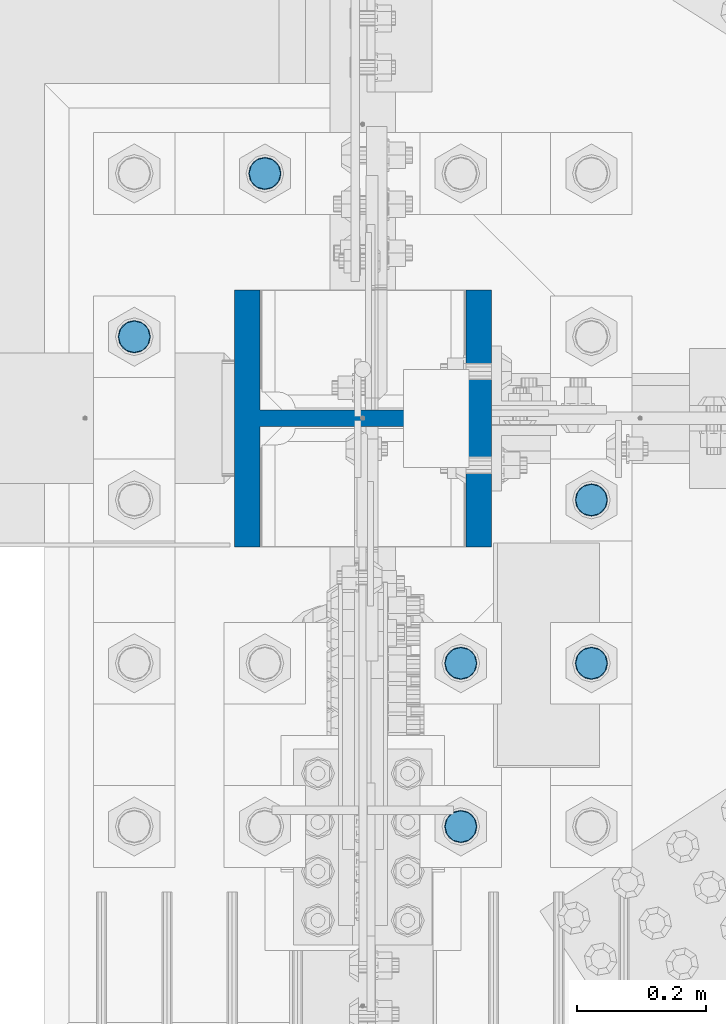
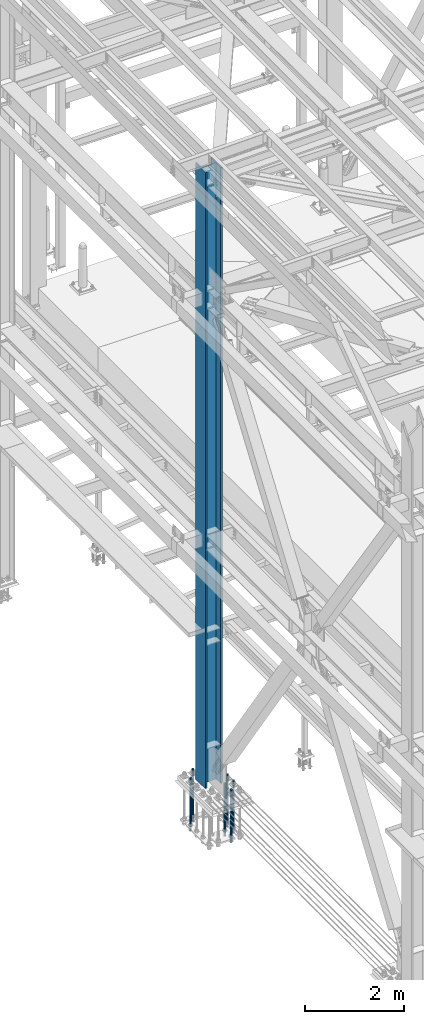
# One storey, part 1358 of 3843: 7 columns, 2 elements without a shape of their own.
"""IFC2X3 building model written with IfcOpenShell, lengths in millimetres."""

from ifc_helpers import new_model, si_unit, frame, origin_with_axes, place, context, subcontext, project, spatial, faceted_brep, material, type_object, element, aggregate, save


model = new_model("IFC2X3")

# Units and contexts
model_context = context("Model", 3, precision=1e-05, world=origin_with_axes())
body_context = subcontext(model_context, "Body", "Model", "MODEL_VIEW")
ifc_project = project(units=[si_unit("LENGTHUNIT", "METRE", prefix="MILLI"), si_unit("AREAUNIT", "SQUARE_METRE"), si_unit("VOLUMEUNIT", "CUBIC_METRE"), si_unit("MASSUNIT", "GRAM", prefix="KILO"), si_unit("TIMEUNIT", "SECOND"), si_unit("PLANEANGLEUNIT", "RADIAN"), si_unit("SOLIDANGLEUNIT", "STERADIAN"), si_unit("THERMODYNAMICTEMPERATUREUNIT", "DEGREE_CELSIUS"), si_unit("LUMINOUSINTENSITYUNIT", "LUMEN")], contexts=[model_context])

# Site, building, storey
site_placement = place(None, origin_with_axes())
site = spatial("IfcSite", under=ifc_project, at=site_placement, CompositionType="ELEMENT")
building_placement = place(site_placement, origin_with_axes())
building = spatial("IfcBuilding", under=site, at=building_placement, Name="Undefined", CompositionType="ELEMENT")
storey_placement = place(building_placement, origin_with_axes())
storey = spatial("IfcBuildingStorey", under=building, at=storey_placement, Name="Undefined", CompositionType="ELEMENT", Elevation=0.0)

# Assembly, columns
assembly_1_placement = place(storey_placement, origin_with_axes())
assembly_1 = element("IfcElementAssembly", 1, at=assembly_1_placement, inside=storey, Name="TEMPLATE", AssemblyPlace="NOTDEFINED", PredefinedType="RIGID_FRAME")
ifc_material_1 = material(Name="Undefined/F1554-GR.55")
column_type_1 = type_object("IfcColumnType", PredefinedType="NOTDEFINED")
column_1_placement = place(assembly_1_placement, frame((36931.6, 75247.5, 30022.8), z_axis=(1.0, 0.0, 0.0), x_axis=(0.0, 0.0, -1.0)))
column_1 = element("IfcColumn", 2, at=column_1_placement, type_object=column_type_1, material=ifc_material_1, Name="ANCHOR_ROD", context=body_context, shape_type="Brep", body=[
    faceted_brep([(-266.700000000001, -21.2176223927236, 12.25), (-266.700000000001, -12.25, 21.2176223927163), (-266.700000000001, 0.0, 24.5), (-266.700000000001, 12.25, 21.2176223927163), (-266.700000000001, 21.2176223927236, 12.25), (-266.700000000001, 24.5, 0.0), (-266.700000000001, 21.2176223927236, -12.25), (-266.700000000001, 12.25, -21.2176223927163), (-266.700000000001, 0.0, -24.5), (-266.700000000001, -12.25, -21.2176223927163), (-266.700000000001, -21.2176223927236, -12.25), (-266.700000000001, -24.5, 0.0), (0.0, 24.5000000000146, 0.0), (0.0, 21.2176223927381, -12.25), (0.0, 12.2500000000146, -21.2176223927163), (0.0, 1.45519152283669e-11, -24.5), (0.0, -12.2499999999854, -21.2176223927163), (0.0, -21.217622392709, -12.25), (0.0, -24.4999999999854, 0.0), (0.0, -21.217622392709, 12.25), (0.0, -12.2499999999854, 21.2176223927163), (0.0, 1.45519152283669e-11, 24.5), (0.0, 12.2500000000146, 21.2176223927163), (0.0, 21.2176223927381, 12.25), (0.0, -23.4665401257807, 9.72015918207035), (0.0, -17.9605122421344, 17.9605122421417), (0.0, -9.72015918207762, 23.466540125788), (0.0, 0.0, 25.4000000000015), (0.0, 9.72015918207762, 23.466540125788), (0.0, 17.9605122421344, 17.9605122421417), (0.0, 23.4665401257807, 9.72015918207035), (0.0, 25.3999996185303, 0.0), (0.0, 23.4665401257807, -9.72015918207035), (0.0, 17.9605122421344, -17.9605122421417), (0.0, 9.72015918207762, -23.466540125788), (0.0, 0.0, -25.4000000000015), (0.0, -9.72015918207762, -23.466540125788), (0.0, -17.9605122421344, -17.9605122421417), (0.0, -23.4665401257807, -9.72015918207035), (0.0, -25.3999996185303, 0.0), (812.799999999999, -25.4000000000015, 0.0), (812.799999999999, -23.466540125788, 9.72015918207398), (812.799999999999, -17.9605122421417, 17.9605122421381), (812.799999999999, -9.72015918207035, 23.466540125788), (812.799999999999, 0.0, 25.4000000000015), (812.799999999999, 9.72015918207035, 23.466540125788), (812.799999999999, 17.9605122421417, 17.9605122421381), (812.799999999999, 23.466540125788, 9.72015918207398), (812.799999999999, 25.4000000000015, 0.0), (812.799999999999, 23.466540125788, -9.72015918207398), (812.799999999999, 17.9605122421417, -17.9605122421381), (812.799999999999, 9.72015918207035, -23.466540125788), (812.799999999999, 0.0, -25.4000000000015), (812.799999999999, -9.72015918207035, -23.466540125788), (812.799999999999, -17.9605122421417, -17.9605122421381), (812.799999999999, -23.466540125788, -9.72015918207398), (812.799999999999, -12.25, 21.2176223927199), (812.799999999999, 0.0, 24.5), (812.799999999999, 12.25, 21.2176223927199), (812.799999999999, 21.2176223927163, 12.25), (812.799999999999, 24.5, 0.0), (812.799999999999, 21.2176223927163, -12.25), (812.799999999999, 12.25, -21.2176223927199), (812.799999999999, 0.0, -24.5), (812.799999999999, -12.25, -21.2176223927199), (812.799999999999, -21.2176223927163, -12.25), (812.799999999999, -24.5, 0.0), (812.799999999999, -21.2176223927163, 12.25), (1041.4, -12.25, -21.2176223927199), (1041.4, 0.0, -24.5), (1041.4, 12.25, -21.2176223927199), (1041.4, 21.2176223927163, -12.25), (1041.4, 24.5, 0.0), (1041.4, 21.2176223927163, 12.25), (1041.4, 12.25, 21.2176223927199), (1041.4, 0.0, 24.5), (1041.4, -12.25, 21.2176223927199), (1041.4, -21.2176223927163, 12.25), (1041.4, -24.5, 0.0), (1041.4, -21.2176223927163, -12.25)], [[[0, 1, 2, 3, 4, 5, 6, 7, 8, 9, 10, 11]], [[6, 5, 12, 13]], [[7, 6, 13, 14]], [[8, 7, 14, 15]], [[9, 8, 15, 16]], [[10, 9, 16, 17]], [[11, 10, 17, 18]], [[0, 11, 18, 19]], [[1, 0, 19, 20]], [[2, 1, 20, 21]], [[3, 2, 21, 22]], [[4, 3, 22, 23]], [[5, 4, 23, 12]], [[24, 25, 26, 27, 28, 29, 30, 31, 32, 33, 34, 35, 36, 37, 38, 39], [22, 21, 20, 19, 18, 17, 16, 15, 14, 13, 12, 23]], [[24, 39, 40, 41]], [[25, 24, 41, 42]], [[26, 25, 42, 43]], [[27, 26, 43, 44]], [[28, 27, 44, 45]], [[29, 28, 45, 46]], [[30, 29, 46, 47]], [[31, 30, 47, 48]], [[32, 31, 48, 49]], [[33, 32, 49, 50]], [[34, 33, 50, 51]], [[35, 34, 51, 52]], [[36, 35, 52, 53]], [[37, 36, 53, 54]], [[38, 37, 54, 55]], [[39, 38, 55, 40]], [[54, 53, 52, 51, 50, 49, 48, 47, 46, 45, 44, 43, 42, 41, 40, 55], [56, 57, 58, 59, 60, 61, 62, 63, 64, 65, 66, 67]], [[68, 69, 70, 71, 72, 73, 74, 75, 76, 77, 78, 79]], [[76, 75, 57, 56]], [[77, 76, 56, 67]], [[78, 77, 67, 66]], [[79, 78, 66, 65]], [[68, 79, 65, 64]], [[69, 68, 64, 63]], [[70, 69, 63, 62]], [[71, 70, 62, 61]], [[72, 71, 61, 60]], [[73, 72, 60, 59]], [[74, 73, 59, 58]], [[75, 74, 58, 57]]]),
])
column_2_placement = place(assembly_1_placement, frame((36931.6, 75501.5, 30022.8), z_axis=(1.0, 0.0, 0.0), x_axis=(0.0, 0.0, -1.0)))
column_2 = element("IfcColumn", 3, at=column_2_placement, type_object=column_type_1, material=ifc_material_1, Name="ANCHOR_ROD", context=body_context, shape_type="Brep", body=[
    faceted_brep([(-266.700000000001, -21.2176223927236, 12.25), (-266.700000000001, -12.25, 21.2176223927163), (-266.700000000001, 0.0, 24.5), (-266.700000000001, 12.25, 21.2176223927163), (-266.700000000001, 21.2176223927236, 12.25), (-266.700000000001, 24.5, 0.0), (-266.700000000001, 21.2176223927236, -12.25), (-266.700000000001, 12.25, -21.2176223927163), (-266.700000000001, 0.0, -24.5), (-266.700000000001, -12.25, -21.2176223927163), (-266.700000000001, -21.2176223927236, -12.25), (-266.700000000001, -24.5, 0.0), (0.0, 24.5000000000146, 0.0), (0.0, 21.2176223927381, -12.25), (0.0, 12.2500000000146, -21.2176223927163), (0.0, 1.45519152283669e-11, -24.5), (0.0, -12.2499999999854, -21.2176223927163), (0.0, -21.217622392709, -12.25), (0.0, -24.4999999999854, 0.0), (0.0, -21.217622392709, 12.25), (0.0, -12.2499999999854, 21.2176223927163), (0.0, 1.45519152283669e-11, 24.5), (0.0, 12.2500000000146, 21.2176223927163), (0.0, 21.2176223927381, 12.25), (0.0, -23.4665401257807, 9.72015918207035), (0.0, -17.9605122421344, 17.9605122421417), (0.0, -9.72015918207762, 23.466540125788), (0.0, 0.0, 25.4000000000015), (0.0, 9.72015918207762, 23.466540125788), (0.0, 17.9605122421344, 17.9605122421417), (0.0, 23.4665401257807, 9.72015918207035), (0.0, 25.3999996185303, 0.0), (0.0, 23.4665401257807, -9.72015918207035), (0.0, 17.9605122421344, -17.9605122421417), (0.0, 9.72015918207762, -23.466540125788), (0.0, 0.0, -25.4000000000015), (0.0, -9.72015918207762, -23.466540125788), (0.0, -17.9605122421344, -17.9605122421417), (0.0, -23.4665401257807, -9.72015918207035), (0.0, -25.3999996185303, 0.0), (812.799999999999, -25.4000000000015, 0.0), (812.799999999999, -23.466540125788, 9.72015918207398), (812.799999999999, -17.9605122421417, 17.9605122421381), (812.799999999999, -9.72015918207035, 23.466540125788), (812.799999999999, 0.0, 25.4000000000015), (812.799999999999, 9.72015918207035, 23.466540125788), (812.799999999999, 17.9605122421417, 17.9605122421381), (812.799999999999, 23.466540125788, 9.72015918207398), (812.799999999999, 25.4000000000015, 0.0), (812.799999999999, 23.466540125788, -9.72015918207398), (812.799999999999, 17.9605122421417, -17.9605122421381), (812.799999999999, 9.72015918207035, -23.466540125788), (812.799999999999, 0.0, -25.4000000000015), (812.799999999999, -9.72015918207035, -23.466540125788), (812.799999999999, -17.9605122421417, -17.9605122421381), (812.799999999999, -23.466540125788, -9.72015918207398), (812.799999999999, -12.25, 21.2176223927199), (812.799999999999, 0.0, 24.5), (812.799999999999, 12.25, 21.2176223927199), (812.799999999999, 21.2176223927163, 12.25), (812.799999999999, 24.5, 0.0), (812.799999999999, 21.2176223927163, -12.25), (812.799999999999, 12.25, -21.2176223927199), (812.799999999999, 0.0, -24.5), (812.799999999999, -12.25, -21.2176223927199), (812.799999999999, -21.2176223927163, -12.25), (812.799999999999, -24.5, 0.0), (812.799999999999, -21.2176223927163, 12.25), (1041.4, -12.25, -21.2176223927199), (1041.4, 0.0, -24.5), (1041.4, 12.25, -21.2176223927199), (1041.4, 21.2176223927163, -12.25), (1041.4, 24.5, 0.0), (1041.4, 21.2176223927163, 12.25), (1041.4, 12.25, 21.2176223927199), (1041.4, 0.0, 24.5), (1041.4, -12.25, 21.2176223927199), (1041.4, -21.2176223927163, 12.25), (1041.4, -24.5, 0.0), (1041.4, -21.2176223927163, -12.25)], [[[0, 1, 2, 3, 4, 5, 6, 7, 8, 9, 10, 11]], [[6, 5, 12, 13]], [[7, 6, 13, 14]], [[8, 7, 14, 15]], [[9, 8, 15, 16]], [[10, 9, 16, 17]], [[11, 10, 17, 18]], [[0, 11, 18, 19]], [[1, 0, 19, 20]], [[2, 1, 20, 21]], [[3, 2, 21, 22]], [[4, 3, 22, 23]], [[5, 4, 23, 12]], [[24, 25, 26, 27, 28, 29, 30, 31, 32, 33, 34, 35, 36, 37, 38, 39], [22, 21, 20, 19, 18, 17, 16, 15, 14, 13, 12, 23]], [[24, 39, 40, 41]], [[25, 24, 41, 42]], [[26, 25, 42, 43]], [[27, 26, 43, 44]], [[28, 27, 44, 45]], [[29, 28, 45, 46]], [[30, 29, 46, 47]], [[31, 30, 47, 48]], [[32, 31, 48, 49]], [[33, 32, 49, 50]], [[34, 33, 50, 51]], [[35, 34, 51, 52]], [[36, 35, 52, 53]], [[37, 36, 53, 54]], [[38, 37, 54, 55]], [[39, 38, 55, 40]], [[54, 53, 52, 51, 50, 49, 48, 47, 46, 45, 44, 43, 42, 41, 40, 55], [56, 57, 58, 59, 60, 61, 62, 63, 64, 65, 66, 67]], [[68, 69, 70, 71, 72, 73, 74, 75, 76, 77, 78, 79]], [[76, 75, 57, 56]], [[77, 76, 56, 67]], [[78, 77, 67, 66]], [[79, 78, 66, 65]], [[68, 79, 65, 64]], [[69, 68, 64, 63]], [[70, 69, 63, 62]], [[71, 70, 62, 61]], [[72, 71, 61, 60]], [[73, 72, 60, 59]], [[74, 73, 59, 58]], [[75, 74, 58, 57]]]),
])
column_3_placement = place(assembly_1_placement, frame((36728.4, 74993.5, 30022.8), z_axis=(1.0, 0.0, 0.0), x_axis=(0.0, 0.0, -1.0)))
column_3 = element("IfcColumn", 4, at=column_3_placement, type_object=column_type_1, material=ifc_material_1, Name="ANCHOR_ROD", context=body_context, shape_type="Brep", body=[
    faceted_brep([(-266.700000000001, -21.2176223927236, 12.25), (-266.700000000001, -12.25, 21.2176223927163), (-266.700000000001, 0.0, 24.5), (-266.700000000001, 12.25, 21.2176223927163), (-266.700000000001, 21.2176223927236, 12.25), (-266.700000000001, 24.5, 0.0), (-266.700000000001, 21.2176223927236, -12.25), (-266.700000000001, 12.25, -21.2176223927163), (-266.700000000001, 0.0, -24.5), (-266.700000000001, -12.25, -21.2176223927163), (-266.700000000001, -21.2176223927236, -12.25), (-266.700000000001, -24.5, 0.0), (0.0, 24.5000000000146, 0.0), (0.0, 21.2176223927381, -12.25), (0.0, 12.2500000000146, -21.2176223927163), (0.0, 1.45519152283669e-11, -24.5), (0.0, -12.2499999999854, -21.2176223927163), (0.0, -21.217622392709, -12.25), (0.0, -24.4999999999854, 0.0), (0.0, -21.217622392709, 12.25), (0.0, -12.2499999999854, 21.2176223927163), (0.0, 1.45519152283669e-11, 24.5), (0.0, 12.2500000000146, 21.2176223927163), (0.0, 21.2176223927381, 12.25), (0.0, -23.4665401257807, 9.72015918207035), (0.0, -17.9605122421344, 17.9605122421417), (0.0, -9.72015918207762, 23.466540125788), (0.0, 0.0, 25.4000000000015), (0.0, 9.72015918207762, 23.466540125788), (0.0, 17.9605122421344, 17.9605122421417), (0.0, 23.4665401257807, 9.72015918207035), (0.0, 25.3999996185303, 0.0), (0.0, 23.4665401257807, -9.72015918207035), (0.0, 17.9605122421344, -17.9605122421417), (0.0, 9.72015918207762, -23.466540125788), (0.0, 0.0, -25.4000000000015), (0.0, -9.72015918207762, -23.466540125788), (0.0, -17.9605122421344, -17.9605122421417), (0.0, -23.4665401257807, -9.72015918207035), (0.0, -25.3999996185303, 0.0), (812.799999999999, -25.4000000000015, 0.0), (812.799999999999, -23.466540125788, 9.72015918207398), (812.799999999999, -17.9605122421417, 17.9605122421381), (812.799999999999, -9.72015918207035, 23.466540125788), (812.799999999999, 0.0, 25.4000000000015), (812.799999999999, 9.72015918207035, 23.466540125788), (812.799999999999, 17.9605122421417, 17.9605122421381), (812.799999999999, 23.466540125788, 9.72015918207398), (812.799999999999, 25.4000000000015, 0.0), (812.799999999999, 23.466540125788, -9.72015918207398), (812.799999999999, 17.9605122421417, -17.9605122421381), (812.799999999999, 9.72015918207035, -23.466540125788), (812.799999999999, 0.0, -25.4000000000015), (812.799999999999, -9.72015918207035, -23.466540125788), (812.799999999999, -17.9605122421417, -17.9605122421381), (812.799999999999, -23.466540125788, -9.72015918207398), (812.799999999999, -12.25, 21.2176223927199), (812.799999999999, 0.0, 24.5), (812.799999999999, 12.25, 21.2176223927199), (812.799999999999, 21.2176223927163, 12.25), (812.799999999999, 24.5, 0.0), (812.799999999999, 21.2176223927163, -12.25), (812.799999999999, 12.25, -21.2176223927199), (812.799999999999, 0.0, -24.5), (812.799999999999, -12.25, -21.2176223927199), (812.799999999999, -21.2176223927163, -12.25), (812.799999999999, -24.5, 0.0), (812.799999999999, -21.2176223927163, 12.25), (1041.4, -12.25, -21.2176223927199), (1041.4, 0.0, -24.5), (1041.4, 12.25, -21.2176223927199), (1041.4, 21.2176223927163, -12.25), (1041.4, 24.5, 0.0), (1041.4, 21.2176223927163, 12.25), (1041.4, 12.25, 21.2176223927199), (1041.4, 0.0, 24.5), (1041.4, -12.25, 21.2176223927199), (1041.4, -21.2176223927163, 12.25), (1041.4, -24.5, 0.0), (1041.4, -21.2176223927163, -12.25)], [[[0, 1, 2, 3, 4, 5, 6, 7, 8, 9, 10, 11]], [[6, 5, 12, 13]], [[7, 6, 13, 14]], [[8, 7, 14, 15]], [[9, 8, 15, 16]], [[10, 9, 16, 17]], [[11, 10, 17, 18]], [[0, 11, 18, 19]], [[1, 0, 19, 20]], [[2, 1, 20, 21]], [[3, 2, 21, 22]], [[4, 3, 22, 23]], [[5, 4, 23, 12]], [[24, 25, 26, 27, 28, 29, 30, 31, 32, 33, 34, 35, 36, 37, 38, 39], [22, 21, 20, 19, 18, 17, 16, 15, 14, 13, 12, 23]], [[24, 39, 40, 41]], [[25, 24, 41, 42]], [[26, 25, 42, 43]], [[27, 26, 43, 44]], [[28, 27, 44, 45]], [[29, 28, 45, 46]], [[30, 29, 46, 47]], [[31, 30, 47, 48]], [[32, 31, 48, 49]], [[33, 32, 49, 50]], [[34, 33, 50, 51]], [[35, 34, 51, 52]], [[36, 35, 52, 53]], [[37, 36, 53, 54]], [[38, 37, 54, 55]], [[39, 38, 55, 40]], [[54, 53, 52, 51, 50, 49, 48, 47, 46, 45, 44, 43, 42, 41, 40, 55], [56, 57, 58, 59, 60, 61, 62, 63, 64, 65, 66, 67]], [[68, 69, 70, 71, 72, 73, 74, 75, 76, 77, 78, 79]], [[76, 75, 57, 56]], [[77, 76, 56, 67]], [[78, 77, 67, 66]], [[79, 78, 66, 65]], [[68, 79, 65, 64]], [[69, 68, 64, 63]], [[70, 69, 63, 62]], [[71, 70, 62, 61]], [[72, 71, 61, 60]], [[73, 72, 60, 59]], [[74, 73, 59, 58]], [[75, 74, 58, 57]]]),
])
column_4_placement = place(assembly_1_placement, frame((36728.4, 75247.5, 30022.8), z_axis=(1.0, 0.0, 0.0), x_axis=(0.0, 0.0, -1.0)))
column_4 = element("IfcColumn", 5, at=column_4_placement, type_object=column_type_1, material=ifc_material_1, Name="ANCHOR_ROD", context=body_context, shape_type="Brep", body=[
    faceted_brep([(-266.700000000001, -21.2176223927236, 12.25), (-266.700000000001, -12.25, 21.2176223927163), (-266.700000000001, 0.0, 24.5), (-266.700000000001, 12.25, 21.2176223927163), (-266.700000000001, 21.2176223927236, 12.25), (-266.700000000001, 24.5, 0.0), (-266.700000000001, 21.2176223927236, -12.25), (-266.700000000001, 12.25, -21.2176223927163), (-266.700000000001, 0.0, -24.5), (-266.700000000001, -12.25, -21.2176223927163), (-266.700000000001, -21.2176223927236, -12.25), (-266.700000000001, -24.5, 0.0), (0.0, 24.5000000000146, 0.0), (0.0, 21.2176223927381, -12.25), (0.0, 12.2500000000146, -21.2176223927163), (0.0, 1.45519152283669e-11, -24.5), (0.0, -12.2499999999854, -21.2176223927163), (0.0, -21.217622392709, -12.25), (0.0, -24.4999999999854, 0.0), (0.0, -21.217622392709, 12.25), (0.0, -12.2499999999854, 21.2176223927163), (0.0, 1.45519152283669e-11, 24.5), (0.0, 12.2500000000146, 21.2176223927163), (0.0, 21.2176223927381, 12.25), (0.0, -23.4665401257807, 9.72015918207035), (0.0, -17.9605122421344, 17.9605122421417), (0.0, -9.72015918207762, 23.466540125788), (0.0, 0.0, 25.4000000000015), (0.0, 9.72015918207762, 23.466540125788), (0.0, 17.9605122421344, 17.9605122421417), (0.0, 23.4665401257807, 9.72015918207035), (0.0, 25.3999996185303, 0.0), (0.0, 23.4665401257807, -9.72015918207035), (0.0, 17.9605122421344, -17.9605122421417), (0.0, 9.72015918207762, -23.466540125788), (0.0, 0.0, -25.4000000000015), (0.0, -9.72015918207762, -23.466540125788), (0.0, -17.9605122421344, -17.9605122421417), (0.0, -23.4665401257807, -9.72015918207035), (0.0, -25.3999996185303, 0.0), (812.799999999999, -25.4000000000015, 0.0), (812.799999999999, -23.466540125788, 9.72015918207398), (812.799999999999, -17.9605122421417, 17.9605122421381), (812.799999999999, -9.72015918207035, 23.466540125788), (812.799999999999, 0.0, 25.4000000000015), (812.799999999999, 9.72015918207035, 23.466540125788), (812.799999999999, 17.9605122421417, 17.9605122421381), (812.799999999999, 23.466540125788, 9.72015918207398), (812.799999999999, 25.4000000000015, 0.0), (812.799999999999, 23.466540125788, -9.72015918207398), (812.799999999999, 17.9605122421417, -17.9605122421381), (812.799999999999, 9.72015918207035, -23.466540125788), (812.799999999999, 0.0, -25.4000000000015), (812.799999999999, -9.72015918207035, -23.466540125788), (812.799999999999, -17.9605122421417, -17.9605122421381), (812.799999999999, -23.466540125788, -9.72015918207398), (812.799999999999, -12.25, 21.2176223927199), (812.799999999999, 0.0, 24.5), (812.799999999999, 12.25, 21.2176223927199), (812.799999999999, 21.2176223927163, 12.25), (812.799999999999, 24.5, 0.0), (812.799999999999, 21.2176223927163, -12.25), (812.799999999999, 12.25, -21.2176223927199), (812.799999999999, 0.0, -24.5), (812.799999999999, -12.25, -21.2176223927199), (812.799999999999, -21.2176223927163, -12.25), (812.799999999999, -24.5, 0.0), (812.799999999999, -21.2176223927163, 12.25), (1041.4, -12.25, -21.2176223927199), (1041.4, 0.0, -24.5), (1041.4, 12.25, -21.2176223927199), (1041.4, 21.2176223927163, -12.25), (1041.4, 24.5, 0.0), (1041.4, 21.2176223927163, 12.25), (1041.4, 12.25, 21.2176223927199), (1041.4, 0.0, 24.5), (1041.4, -12.25, 21.2176223927199), (1041.4, -21.2176223927163, 12.25), (1041.4, -24.5, 0.0), (1041.4, -21.2176223927163, -12.25)], [[[0, 1, 2, 3, 4, 5, 6, 7, 8, 9, 10, 11]], [[6, 5, 12, 13]], [[7, 6, 13, 14]], [[8, 7, 14, 15]], [[9, 8, 15, 16]], [[10, 9, 16, 17]], [[11, 10, 17, 18]], [[0, 11, 18, 19]], [[1, 0, 19, 20]], [[2, 1, 20, 21]], [[3, 2, 21, 22]], [[4, 3, 22, 23]], [[5, 4, 23, 12]], [[24, 25, 26, 27, 28, 29, 30, 31, 32, 33, 34, 35, 36, 37, 38, 39], [22, 21, 20, 19, 18, 17, 16, 15, 14, 13, 12, 23]], [[24, 39, 40, 41]], [[25, 24, 41, 42]], [[26, 25, 42, 43]], [[27, 26, 43, 44]], [[28, 27, 44, 45]], [[29, 28, 45, 46]], [[30, 29, 46, 47]], [[31, 30, 47, 48]], [[32, 31, 48, 49]], [[33, 32, 49, 50]], [[34, 33, 50, 51]], [[35, 34, 51, 52]], [[36, 35, 52, 53]], [[37, 36, 53, 54]], [[38, 37, 54, 55]], [[39, 38, 55, 40]], [[54, 53, 52, 51, 50, 49, 48, 47, 46, 45, 44, 43, 42, 41, 40, 55], [56, 57, 58, 59, 60, 61, 62, 63, 64, 65, 66, 67]], [[68, 69, 70, 71, 72, 73, 74, 75, 76, 77, 78, 79]], [[76, 75, 57, 56]], [[77, 76, 56, 67]], [[78, 77, 67, 66]], [[79, 78, 66, 65]], [[68, 79, 65, 64]], [[69, 68, 64, 63]], [[70, 69, 63, 62]], [[71, 70, 62, 61]], [[72, 71, 61, 60]], [[73, 72, 60, 59]], [[74, 73, 59, 58]], [[75, 74, 58, 57]]]),
])
column_5_placement = place(assembly_1_placement, frame((36423.6, 76009.5, 30022.8), z_axis=(-1.0, 0.0, 0.0), x_axis=(0.0, 0.0, -1.0)))
column_5 = element("IfcColumn", 6, at=column_5_placement, type_object=column_type_1, material=ifc_material_1, Name="ANCHOR_ROD", context=body_context, shape_type="Brep", body=[
    faceted_brep([(-266.700000000001, -21.2176223927236, 12.25), (-266.700000000001, -12.25, 21.2176223927163), (-266.700000000001, 0.0, 24.5), (-266.700000000001, 12.25, 21.2176223927163), (-266.700000000001, 21.2176223927236, 12.25), (-266.700000000001, 24.5, 0.0), (-266.700000000001, 21.2176223927236, -12.25), (-266.700000000001, 12.25, -21.2176223927163), (-266.700000000001, 0.0, -24.5), (-266.700000000001, -12.25, -21.2176223927163), (-266.700000000001, -21.2176223927236, -12.25), (-266.700000000001, -24.5, 0.0), (0.0, 24.5000000000146, 0.0), (0.0, 21.2176223927381, -12.25), (0.0, 12.2500000000146, -21.2176223927163), (0.0, 1.45519152283669e-11, -24.5), (0.0, -12.2499999999854, -21.2176223927163), (0.0, -21.217622392709, -12.25), (0.0, -24.4999999999854, 0.0), (0.0, -21.217622392709, 12.25), (0.0, -12.2499999999854, 21.2176223927163), (0.0, 1.45519152283669e-11, 24.5), (0.0, 12.2500000000146, 21.2176223927163), (0.0, 21.2176223927381, 12.25), (0.0, -23.4665401257807, 9.72015918207035), (0.0, -17.9605122421344, 17.9605122421417), (0.0, -9.72015918207762, 23.466540125788), (0.0, 0.0, 25.4000000000015), (0.0, 9.72015918207762, 23.466540125788), (0.0, 17.9605122421344, 17.9605122421417), (0.0, 23.4665401257807, 9.72015918207035), (0.0, 25.3999996185303, 0.0), (0.0, 23.4665401257807, -9.72015918207035), (0.0, 17.9605122421344, -17.9605122421417), (0.0, 9.72015918207762, -23.466540125788), (0.0, 0.0, -25.4000000000015), (0.0, -9.72015918207762, -23.466540125788), (0.0, -17.9605122421344, -17.9605122421417), (0.0, -23.4665401257807, -9.72015918207035), (0.0, -25.3999996185303, 0.0), (812.799999999999, -25.4000000000015, 0.0), (812.799999999999, -23.466540125788, 9.72015918207398), (812.799999999999, -17.9605122421417, 17.9605122421381), (812.799999999999, -9.72015918207035, 23.466540125788), (812.799999999999, 0.0, 25.4000000000015), (812.799999999999, 9.72015918207035, 23.466540125788), (812.799999999999, 17.9605122421417, 17.9605122421381), (812.799999999999, 23.466540125788, 9.72015918207398), (812.799999999999, 25.4000000000015, 0.0), (812.799999999999, 23.466540125788, -9.72015918207398), (812.799999999999, 17.9605122421417, -17.9605122421381), (812.799999999999, 9.72015918207035, -23.466540125788), (812.799999999999, 0.0, -25.4000000000015), (812.799999999999, -9.72015918207035, -23.466540125788), (812.799999999999, -17.9605122421417, -17.9605122421381), (812.799999999999, -23.466540125788, -9.72015918207398), (812.799999999999, -12.25, 21.2176223927199), (812.799999999999, 0.0, 24.5), (812.799999999999, 12.25, 21.2176223927199), (812.799999999999, 21.2176223927163, 12.25), (812.799999999999, 24.5, 0.0), (812.799999999999, 21.2176223927163, -12.25), (812.799999999999, 12.25, -21.2176223927199), (812.799999999999, 0.0, -24.5), (812.799999999999, -12.25, -21.2176223927199), (812.799999999999, -21.2176223927163, -12.25), (812.799999999999, -24.5, 0.0), (812.799999999999, -21.2176223927163, 12.25), (1041.4, -12.25, -21.2176223927199), (1041.4, 0.0, -24.5), (1041.4, 12.25, -21.2176223927199), (1041.4, 21.2176223927163, -12.25), (1041.4, 24.5, 0.0), (1041.4, 21.2176223927163, 12.25), (1041.4, 12.25, 21.2176223927199), (1041.4, 0.0, 24.5), (1041.4, -12.25, 21.2176223927199), (1041.4, -21.2176223927163, 12.25), (1041.4, -24.5, 0.0), (1041.4, -21.2176223927163, -12.25)], [[[0, 1, 2, 3, 4, 5, 6, 7, 8, 9, 10, 11]], [[6, 5, 12, 13]], [[7, 6, 13, 14]], [[8, 7, 14, 15]], [[9, 8, 15, 16]], [[10, 9, 16, 17]], [[11, 10, 17, 18]], [[0, 11, 18, 19]], [[1, 0, 19, 20]], [[2, 1, 20, 21]], [[3, 2, 21, 22]], [[4, 3, 22, 23]], [[5, 4, 23, 12]], [[24, 25, 26, 27, 28, 29, 30, 31, 32, 33, 34, 35, 36, 37, 38, 39], [22, 21, 20, 19, 18, 17, 16, 15, 14, 13, 12, 23]], [[24, 39, 40, 41]], [[25, 24, 41, 42]], [[26, 25, 42, 43]], [[27, 26, 43, 44]], [[28, 27, 44, 45]], [[29, 28, 45, 46]], [[30, 29, 46, 47]], [[31, 30, 47, 48]], [[32, 31, 48, 49]], [[33, 32, 49, 50]], [[34, 33, 50, 51]], [[35, 34, 51, 52]], [[36, 35, 52, 53]], [[37, 36, 53, 54]], [[38, 37, 54, 55]], [[39, 38, 55, 40]], [[54, 53, 52, 51, 50, 49, 48, 47, 46, 45, 44, 43, 42, 41, 40, 55], [56, 57, 58, 59, 60, 61, 62, 63, 64, 65, 66, 67]], [[68, 69, 70, 71, 72, 73, 74, 75, 76, 77, 78, 79]], [[76, 75, 57, 56]], [[77, 76, 56, 67]], [[78, 77, 67, 66]], [[79, 78, 66, 65]], [[68, 79, 65, 64]], [[69, 68, 64, 63]], [[70, 69, 63, 62]], [[71, 70, 62, 61]], [[72, 71, 61, 60]], [[73, 72, 60, 59]], [[74, 73, 59, 58]], [[75, 74, 58, 57]]]),
])
column_6_placement = place(assembly_1_placement, frame((36220.4, 75755.5, 30022.8), z_axis=(-1.0, 0.0, 0.0), x_axis=(0.0, 0.0, -1.0)))
column_6 = element("IfcColumn", 7, at=column_6_placement, type_object=column_type_1, material=ifc_material_1, Name="ANCHOR_ROD", context=body_context, shape_type="Brep", body=[
    faceted_brep([(-266.700000000001, -21.2176223927236, 12.25), (-266.700000000001, -12.25, 21.2176223927163), (-266.700000000001, 0.0, 24.5), (-266.700000000001, 12.25, 21.2176223927163), (-266.700000000001, 21.2176223927236, 12.25), (-266.700000000001, 24.5, 0.0), (-266.700000000001, 21.2176223927236, -12.25), (-266.700000000001, 12.25, -21.2176223927163), (-266.700000000001, 0.0, -24.5), (-266.700000000001, -12.25, -21.2176223927163), (-266.700000000001, -21.2176223927236, -12.25), (-266.700000000001, -24.5, 0.0), (0.0, 24.5000000000146, 0.0), (0.0, 21.2176223927381, -12.25), (0.0, 12.2500000000146, -21.2176223927163), (0.0, 1.45519152283669e-11, -24.5), (0.0, -12.2499999999854, -21.2176223927163), (0.0, -21.217622392709, -12.25), (0.0, -24.4999999999854, 0.0), (0.0, -21.217622392709, 12.25), (0.0, -12.2499999999854, 21.2176223927163), (0.0, 1.45519152283669e-11, 24.5), (0.0, 12.2500000000146, 21.2176223927163), (0.0, 21.2176223927381, 12.25), (0.0, -23.4665401257807, 9.72015918207035), (0.0, -17.9605122421344, 17.9605122421417), (0.0, -9.72015918207762, 23.466540125788), (0.0, 0.0, 25.4000000000015), (0.0, 9.72015918207762, 23.466540125788), (0.0, 17.9605122421344, 17.9605122421417), (0.0, 23.4665401257807, 9.72015918207035), (0.0, 25.3999996185303, 0.0), (0.0, 23.4665401257807, -9.72015918207035), (0.0, 17.9605122421344, -17.9605122421417), (0.0, 9.72015918207762, -23.466540125788), (0.0, 0.0, -25.4000000000015), (0.0, -9.72015918207762, -23.466540125788), (0.0, -17.9605122421344, -17.9605122421417), (0.0, -23.4665401257807, -9.72015918207035), (0.0, -25.3999996185303, 0.0), (812.799999999999, -25.4000000000015, 0.0), (812.799999999999, -23.466540125788, 9.72015918207398), (812.799999999999, -17.9605122421417, 17.9605122421381), (812.799999999999, -9.72015918207035, 23.466540125788), (812.799999999999, 0.0, 25.4000000000015), (812.799999999999, 9.72015918207035, 23.466540125788), (812.799999999999, 17.9605122421417, 17.9605122421381), (812.799999999999, 23.466540125788, 9.72015918207398), (812.799999999999, 25.4000000000015, 0.0), (812.799999999999, 23.466540125788, -9.72015918207398), (812.799999999999, 17.9605122421417, -17.9605122421381), (812.799999999999, 9.72015918207035, -23.466540125788), (812.799999999999, 0.0, -25.4000000000015), (812.799999999999, -9.72015918207035, -23.466540125788), (812.799999999999, -17.9605122421417, -17.9605122421381), (812.799999999999, -23.466540125788, -9.72015918207398), (812.799999999999, -12.25, 21.2176223927199), (812.799999999999, 0.0, 24.5), (812.799999999999, 12.25, 21.2176223927199), (812.799999999999, 21.2176223927163, 12.25), (812.799999999999, 24.5, 0.0), (812.799999999999, 21.2176223927163, -12.25), (812.799999999999, 12.25, -21.2176223927199), (812.799999999999, 0.0, -24.5), (812.799999999999, -12.25, -21.2176223927199), (812.799999999999, -21.2176223927163, -12.25), (812.799999999999, -24.5, 0.0), (812.799999999999, -21.2176223927163, 12.25), (1041.4, -12.25, -21.2176223927199), (1041.4, 0.0, -24.5), (1041.4, 12.25, -21.2176223927199), (1041.4, 21.2176223927163, -12.25), (1041.4, 24.5, 0.0), (1041.4, 21.2176223927163, 12.25), (1041.4, 12.25, 21.2176223927199), (1041.4, 0.0, 24.5), (1041.4, -12.25, 21.2176223927199), (1041.4, -21.2176223927163, 12.25), (1041.4, -24.5, 0.0), (1041.4, -21.2176223927163, -12.25)], [[[0, 1, 2, 3, 4, 5, 6, 7, 8, 9, 10, 11]], [[6, 5, 12, 13]], [[7, 6, 13, 14]], [[8, 7, 14, 15]], [[9, 8, 15, 16]], [[10, 9, 16, 17]], [[11, 10, 17, 18]], [[0, 11, 18, 19]], [[1, 0, 19, 20]], [[2, 1, 20, 21]], [[3, 2, 21, 22]], [[4, 3, 22, 23]], [[5, 4, 23, 12]], [[24, 25, 26, 27, 28, 29, 30, 31, 32, 33, 34, 35, 36, 37, 38, 39], [22, 21, 20, 19, 18, 17, 16, 15, 14, 13, 12, 23]], [[24, 39, 40, 41]], [[25, 24, 41, 42]], [[26, 25, 42, 43]], [[27, 26, 43, 44]], [[28, 27, 44, 45]], [[29, 28, 45, 46]], [[30, 29, 46, 47]], [[31, 30, 47, 48]], [[32, 31, 48, 49]], [[33, 32, 49, 50]], [[34, 33, 50, 51]], [[35, 34, 51, 52]], [[36, 35, 52, 53]], [[37, 36, 53, 54]], [[38, 37, 54, 55]], [[39, 38, 55, 40]], [[54, 53, 52, 51, 50, 49, 48, 47, 46, 45, 44, 43, 42, 41, 40, 55], [56, 57, 58, 59, 60, 61, 62, 63, 64, 65, 66, 67]], [[68, 69, 70, 71, 72, 73, 74, 75, 76, 77, 78, 79]], [[76, 75, 57, 56]], [[77, 76, 56, 67]], [[78, 77, 67, 66]], [[79, 78, 66, 65]], [[68, 79, 65, 64]], [[69, 68, 64, 63]], [[70, 69, 63, 62]], [[71, 70, 62, 61]], [[72, 71, 61, 60]], [[73, 72, 60, 59]], [[74, 73, 59, 58]], [[75, 74, 58, 57]]]),
])
aggregate(assembly_1, [column_1, column_2, column_3, column_4, column_5, column_6])

# Assembly, column
assembly_2_placement = place(storey_placement, origin_with_axes())
assembly_2 = element("IfcElementAssembly", 8, at=assembly_2_placement, inside=storey, Name="COLUMN", AssemblyPlace="NOTDEFINED", PredefinedType="RIGID_FRAME")
ifc_material_2 = material(Name="STEEL/A992")
column_type_2 = type_object("IfcColumnType", Name="W14X211", PredefinedType="NOTDEFINED")
column_7_placement = place(assembly_2_placement, frame((36576.0, 75628.5, 30022.8), z_axis=(-1.0, 0.0, 0.0), x_axis=(0.0, 0.0, 1.0)))
column_7 = element("IfcColumn", 9, at=column_7_placement, type_object=column_type_2, material=ifc_material_2, Name="COLUMN", ObjectType="W14X211", context=body_context, shape_type="Brep", body=[
    faceted_brep([(139.700000000008, -200.025000000001, -200.025000000001), (139.700000000008, -200.025000000001, -160.337500000001), (139.700000000008, -12.6999999999971, -160.337500000001), (139.700000000008, -12.6999999999971, 160.337500000001), (139.700000000008, -200.025000000001, 160.337500000001), (139.700000000008, -200.025000000001, 200.025000000001), (139.700000000008, 200.025000000001, 200.025000000001), (139.700000000008, 200.025000000001, 160.337500000001), (139.700000000008, 12.6999999999971, 160.337500000001), (139.700000000008, 12.6999999999971, -160.337500000001), (139.700000000008, 200.025000000001, -160.337500000001), (139.700000000008, 200.025000000001, -200.025000000001), (15377.4712377557, -200.024999999994, 200.025000000001), (15377.4712377557, 200.024999999994, 200.025000000001), (15377.4712377557, 200.024999999994, 160.337500000001), (15377.4712377557, 12.6999999999971, 160.337500000001), (15377.4712377557, 12.6999999999971, -160.337500000001), (15377.4712377557, 200.024999999994, -160.337500000001), (15377.4712377557, 200.024999999994, -200.025000000001), (15377.4712377557, -200.024999999994, -200.025000000001), (15377.4712377557, -200.024999999994, -160.337500000001), (15377.4712377557, -12.6999999999971, -160.337500000001), (15377.4712377557, -12.6999999999971, 160.337500000001), (15377.4712377557, -200.024999999994, 160.337500000001)], [[[0, 1, 2, 3, 4, 5, 6, 7, 8, 9, 10, 11]], [[6, 5, 12, 13]], [[7, 6, 13, 14]], [[8, 7, 14, 15]], [[9, 8, 15, 16]], [[10, 9, 16, 17]], [[11, 10, 17, 18]], [[0, 11, 18, 19]], [[1, 0, 19, 20]], [[2, 1, 20, 21]], [[3, 2, 21, 22]], [[4, 3, 22, 23]], [[5, 4, 23, 12]], [[22, 21, 20, 19, 18, 17, 16, 15, 14, 13, 12, 23]]]),
])
aggregate(assembly_2, [column_7])

save(model, "model.ifc")
